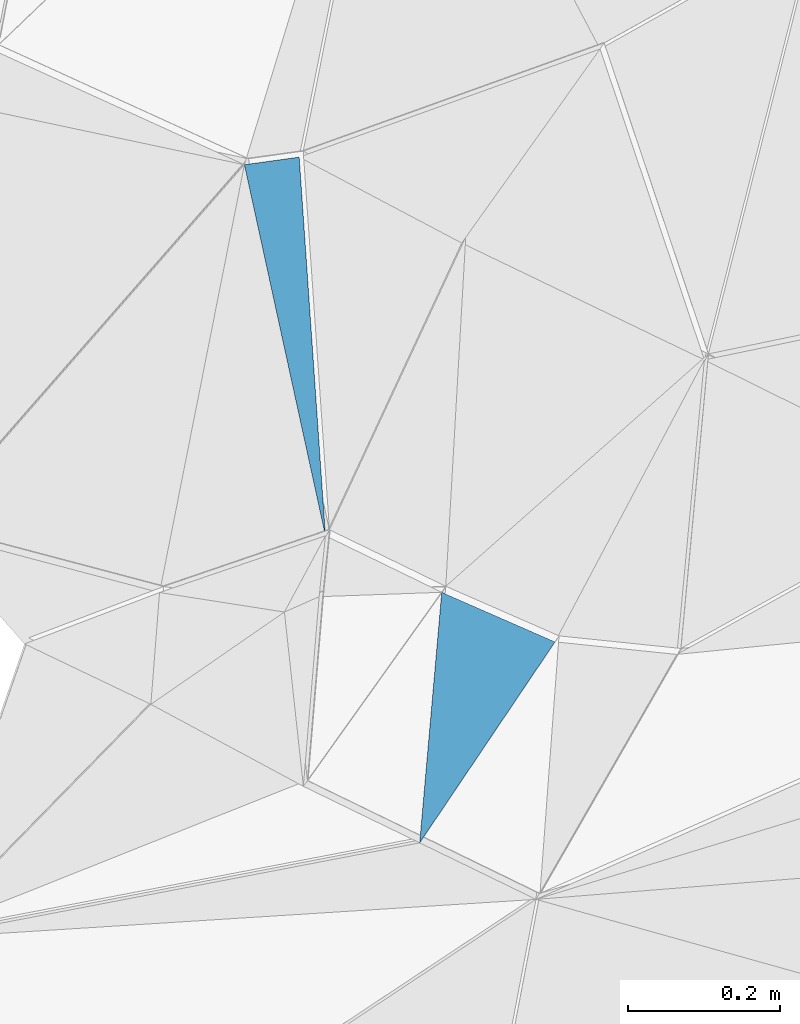
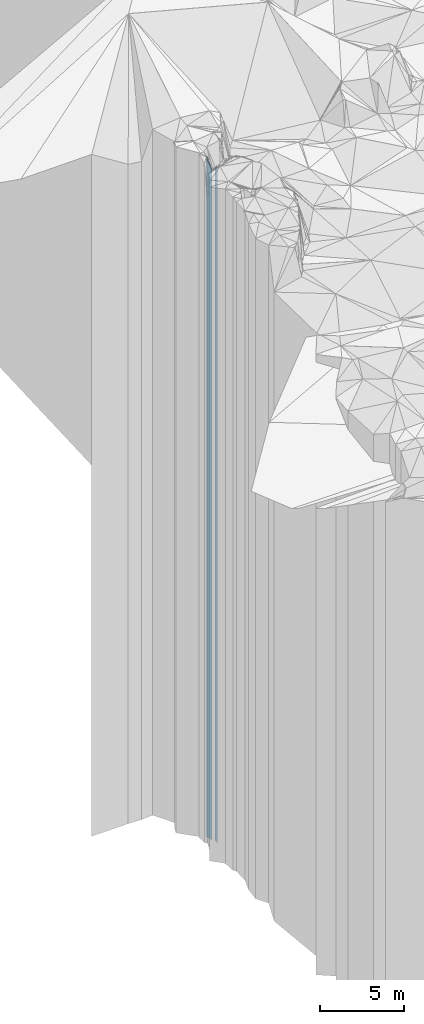
# One storey, part 232 of 275: 2 plates.
"""IFC2X3 building model written with IfcOpenShell, lengths in millimetres."""

import ifcopenshell
import ifcopenshell.guid

model = None  # the IFC model being written
_history = None  # IfcOwnerHistory: only IFC2X3 demands one
_inside = {}  # id of a spatial element -> (the spatial element, [elements in it])
_under = {}  # id of a project, library or spatial element -> (it, [spatial elements below it])
_declared = {}  # id of a project -> (the project, [libraries it declares])
_typed = {}  # id of a type object -> (the type object, [elements of that type])
_made_of = {}  # id of a material, layer set ... -> (it, [elements and type objects made of it])


def new_model(schema):
    """Start an empty IFC model of exactly this schema.

    Asked for "IFC4X3", IfcOpenShell would pick the latest addendum, in which some entities
    have other attributes; the version numbers below select the first issue.
    IFC2X3 requires an IfcOwnerHistory on every rooted entity: one is made here for all.
    """
    global model, _history
    if schema == "IFC4X3":
        model = ifcopenshell.file(schema_version=(4, 3, 0, 0))
    else:
        model = ifcopenshell.file(schema=schema)
    _inside.clear()
    _under.clear()
    _declared.clear()
    _typed.clear()
    _made_of.clear()
    _history = None
    if model.schema == "IFC2X3":
        org = make("IfcOrganization", Name="unknown")
        user = make(
            "IfcPersonAndOrganization",
            ThePerson=make("IfcPerson", FamilyName="unknown"),
            TheOrganization=org,
        )
        app = make(
            "IfcApplication",
            ApplicationDeveloper=org,
            Version="unknown",
            ApplicationFullName="unknown",
            ApplicationIdentifier="unknown",
        )
        _history = make(
            "IfcOwnerHistory",
            OwningUser=user,
            OwningApplication=app,
            ChangeAction="ADDED",
            CreationDate=0,
        )
    return model


def make(cls, **values):
    """One entity of the class cls with the attributes given. An attribute that is None is left unset."""
    return model.create_entity(
        cls, **{name: value for name, value in values.items() if value is not None}
    )


def rooted(cls, **values):
    """An entity with a GlobalId (a new one), such as an element, a storey or a relation."""
    return make(cls, GlobalId=ifcopenshell.guid.new(), OwnerHistory=_history, **values)


def si_unit(unit_type, name, prefix=None):
    """IfcSIUnit, for example si_unit("LENGTHUNIT", "METRE", prefix="MILLI")."""
    return make("IfcSIUnit", UnitType=unit_type, Prefix=prefix, Name=name)


def assignment(units):
    """IfcUnitAssignment: the units of a project."""
    return None if units is None else make("IfcUnitAssignment", Units=units)


def point(xyz):
    """IfcCartesianPoint."""
    return None if xyz is None else make("IfcCartesianPoint", Coordinates=xyz)


def direction(xyz):
    """IfcDirection."""
    return None if xyz is None else make("IfcDirection", DirectionRatios=xyz)


def frame(location, z_axis=None, x_axis=None):
    """IfcAxis2Placement3D, a coordinate frame: its origin and axes. An axis left out is left unset."""
    return make(
        "IfcAxis2Placement3D",
        Location=point(location),
        Axis=direction(z_axis),
        RefDirection=direction(x_axis),
    )


def origin_with_axes():
    """The frame at (0, 0, 0) with the z axis (0, 0, 1) and the x axis (1, 0, 0) written out."""
    return frame((0.0, 0.0, 0.0), z_axis=(0.0, 0.0, 1.0), x_axis=(1.0, 0.0, 0.0))


def place(relative_to, where):
    """IfcLocalPlacement: puts the frame where relative to a parent placement (None: the world)."""
    return make(
        "IfcLocalPlacement", PlacementRelTo=relative_to, RelativePlacement=where
    )


def context(
    kind, dimensions, precision=None, world=None, true_north=None, identifier=None
):
    """IfcGeometricRepresentationContext, for example the 3D "Model" context."""
    return make(
        "IfcGeometricRepresentationContext",
        ContextIdentifier=identifier,
        ContextType=kind,
        CoordinateSpaceDimension=dimensions,
        Precision=precision,
        WorldCoordinateSystem=world,
        TrueNorth=true_north,
    )


def subcontext(parent, identifier, kind, view, scale=None):
    """IfcGeometricRepresentationSubContext, for example "Body" below "Model"."""
    return make(
        "IfcGeometricRepresentationSubContext",
        ContextIdentifier=identifier,
        ContextType=kind,
        ParentContext=parent,
        TargetScale=scale,
        TargetView=view,
    )


def project(units=None, contexts=None):
    """IfcProject with its units and contexts."""
    return rooted(
        "IfcProject",
        Name="project",
        RepresentationContexts=contexts,
        UnitsInContext=assignment(units),
    )


def spatial(cls, under=None, at=None, **own):
    """A site, building, storey or space (cls), placed at a placement, below another one or the project."""
    s = rooted(cls, ObjectPlacement=at, **own)
    if under is not None:
        _under.setdefault(under.id(), (under, []))[1].append(s)
    return s


def faces_of(points, faces, orient=None, outer=None):
    """IfcFace entities. A face is a list of loops; a loop is a list of indices into points, from 0.

    orient and outer hold one flag for each loop. By default every Orientation is true, the
    first loop of a face is its IfcFaceOuterBound and the others are IfcFaceBound.
    """
    made = []
    for i, loops in enumerate(faces):
        bounds = []
        for j, loop in enumerate(loops):
            is_outer = j == 0 if outer is None else outer[i][j]
            bounds.append(
                make(
                    "IfcFaceOuterBound" if is_outer else "IfcFaceBound",
                    Bound=make("IfcPolyLoop", Polygon=[points[k] for k in loop]),
                    Orientation=True if orient is None else orient[i][j],
                )
            )
        made.append(make("IfcFace", Bounds=bounds))
    return made


def faceted_brep(points, faces, orient=None, outer=None, voids=None):
    """IfcFacetedBrep: a solid bounded by flat faces; with voids (closed shells), ...WithVoids."""
    shared = [point(p) for p in points]
    hull = make("IfcClosedShell", CfsFaces=faces_of(shared, faces, orient, outer))
    if voids is None:
        return make("IfcFacetedBrep", Outer=hull)
    return make(
        "IfcFacetedBrepWithVoids",
        Outer=hull,
        Voids=[
            make(cls, CfsFaces=faces_of(shared, fs, o, b)) for cls, fs, o, b in voids
        ],
    )


def shape(context_of_items, identifier, shape_type, items):
    """IfcShapeRepresentation: the items that make up one representation, for example the "Body"."""
    return make(
        "IfcShapeRepresentation",
        ContextOfItems=context_of_items,
        RepresentationIdentifier=identifier,
        RepresentationType=shape_type,
        Items=items,
    )


def material(Name=None, Category=None):
    """IfcMaterial."""
    return make("IfcMaterial", Name=Name, Category=Category)


def made_of(thing, what):
    """Note that an element or type object is made of a material, layer set ...; save() writes the relation."""
    if what is not None:
        _made_of.setdefault(what.id(), (what, []))[1].append(thing)
    return thing


def type_object(cls, material=None, **own):
    """A type object (cls), such as IfcWallType, which elements share."""
    return made_of(rooted(cls, **own), material)


def element(
    cls,
    number,
    at=None,
    inside=None,
    cuts=None,
    type_object=None,
    material=None,
    context=None,
    identifier="Body",
    shape_type=None,
    held_by="IfcProductDefinitionShape",
    body=None,
    shapes=None,
    **own,
):
    """One element of the class cls, such as IfcWall. Its Tag is "e" and its number.

    at: its placement. inside: the storey or other place that contains it. cuts: it is an
    opening in that element (IfcRelVoidsElement). A single representation is given by context,
    identifier, shape_type and body (its items); several are given by shapes. held_by: the class
    of the entity that holds the representations. save() writes the other relations.
    """
    e = rooted(cls, Tag="e%d" % number, ObjectPlacement=at, **own)
    if body is not None:
        shapes = [shape(context, identifier, shape_type, body)]
    if shapes is not None:
        e.Representation = make(held_by, Representations=shapes)
    if inside is not None:
        _inside.setdefault(inside.id(), (inside, []))[1].append(e)
    if cuts is not None:
        rooted(
            "IfcRelVoidsElement", RelatingBuildingElement=cuts, RelatedOpeningElement=e
        )
    if type_object is not None:
        _typed.setdefault(type_object.id(), (type_object, []))[1].append(e)
    return made_of(e, material)


def aggregate(whole, parts):
    """IfcRelAggregates: a whole, such as a stair, and the parts it consists of."""
    return rooted("IfcRelAggregates", RelatingObject=whole, RelatedObjects=parts)


def save(model, path):
    """Write the relations noted so far, then the file.

    IfcRelAggregates (storeys below a building ...), IfcRelContainedInSpatialStructure (elements
    in a storey), IfcRelDefinesByType, IfcRelAssociatesMaterial and IfcRelDeclares: one each for
    every whole, place, type object, material and project.
    """
    for whole, parts in _under.values():
        aggregate(whole, parts)
    for where, things in _inside.values():
        rooted(
            "IfcRelContainedInSpatialStructure",
            RelatedElements=things,
            RelatingStructure=where,
        )
    for kind, things in _typed.values():
        rooted("IfcRelDefinesByType", RelatedObjects=things, RelatingType=kind)
    for what, things in _made_of.values():
        rooted("IfcRelAssociatesMaterial", RelatedObjects=things, RelatingMaterial=what)
    for by, libraries in _declared.values():
        rooted("IfcRelDeclares", RelatingContext=by, RelatedDefinitions=libraries)
    model.write(path)


model = new_model("IFC2X3")

# Units and contexts
model_context = context("Model", 3, precision=1e-05, world=origin_with_axes())
body_context = subcontext(model_context, "Body", "Model", "MODEL_VIEW")
ifc_project = project(units=[si_unit("LENGTHUNIT", "METRE", prefix="MILLI"), si_unit("AREAUNIT", "SQUARE_METRE"), si_unit("VOLUMEUNIT", "CUBIC_METRE"), si_unit("MASSUNIT", "GRAM", prefix="KILO"), si_unit("TIMEUNIT", "SECOND"), si_unit("PLANEANGLEUNIT", "RADIAN"), si_unit("SOLIDANGLEUNIT", "STERADIAN"), si_unit("THERMODYNAMICTEMPERATUREUNIT", "DEGREE_CELSIUS"), si_unit("LUMINOUSINTENSITYUNIT", "LUMEN")], contexts=[model_context])

# Site, building, storey
site_placement = place(None, origin_with_axes())
site = spatial("IfcSite", under=ifc_project, at=site_placement, CompositionType="ELEMENT")
building_placement = place(site_placement, origin_with_axes())
building = spatial("IfcBuilding", under=site, at=building_placement, Name="Undefined", CompositionType="ELEMENT")
storey_placement = place(building_placement, origin_with_axes())
storey = spatial("IfcBuildingStorey", under=building, at=storey_placement, Name="Undefined", CompositionType="ELEMENT", Elevation=0.0)

# Plates
ifc_material = material()
plate_type_1 = type_object("IfcPlateType", PredefinedType="NOTDEFINED")
plate_1_placement = place(storey_placement, frame((-137738.316629679, 92565.7459972227, 32074.0), z_axis=(0.137581187998987, -0.990490492992632, 0.0), x_axis=(-0.990490492992625, -0.137581187999038, 0.0)))
element("IfcPlate", 1, at=plate_1_placement, inside=storey, type_object=plate_type_1, material=ifc_material, Name="00", context=body_context, shape_type="Brep", body=[
    faceted_brep([(0.0, -24886.0, 2.91038304567337e-11), (34.3401412963431, -24246.0, 498.618835449219), (34.3401412963431, 24246.0, 498.618835449219), (0.0, 24246.0, 1.45519152283669e-11), (72.8011016845558, -24916.0, -3.20142135024071e-10), (72.8011016845558, 24246.0, -3.20142135024071e-10)], [[[0, 1, 2, 3]], [[1, 4, 5, 2]], [[4, 0, 3, 5]], [[5, 3, 2]], [[4, 1, 0]]]),
])
plate_type_2 = type_object("IfcPlateType", PredefinedType="NOTDEFINED")
plate_2_placement = place(storey_placement, frame((-137579.612398547, 91662.7991731955, 32164.0), z_axis=(-0.829515828344418, 0.558483205231879, 0.0), x_axis=(0.558483205231892, 0.82951582834441, 0.0)))
element("IfcPlate", 2, at=plate_2_placement, inside=storey, type_object=plate_type_2, material=ifc_material, Name="00", context=body_context, shape_type="Brep", body=[
    faceted_brep([(2.91038304567337e-11, -24576.0, 1.45519152283669e-11), (289.91311645509, -24336.0, 160.15739440918), (289.91311645509, 24336.0, 160.15739440918), (1.20508047984913e-11, 24336.0, 0.0), (319.061126708982, -24356.0, 2.29920260608196e-09), (319.061126708982, 24336.0, 2.29920260608196e-09)], [[[0, 1, 2, 3]], [[1, 4, 5, 2]], [[4, 0, 3, 5]], [[5, 3, 2]], [[4, 1, 0]]]),
])

save(model, "model.ifc")
